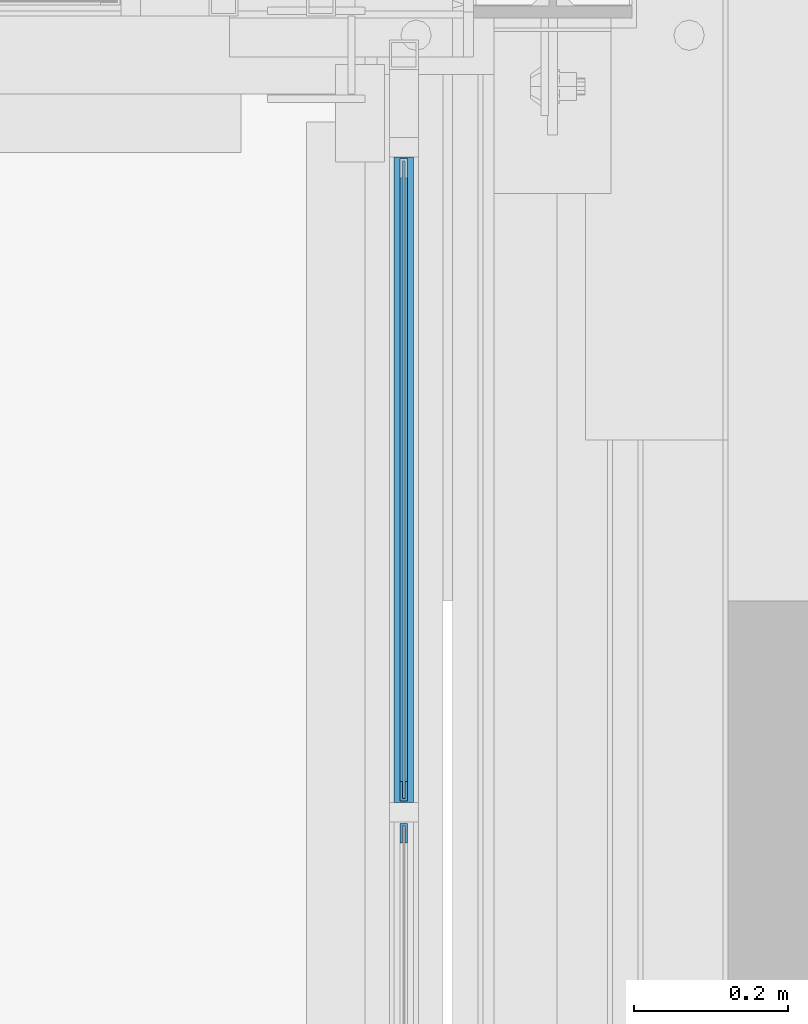
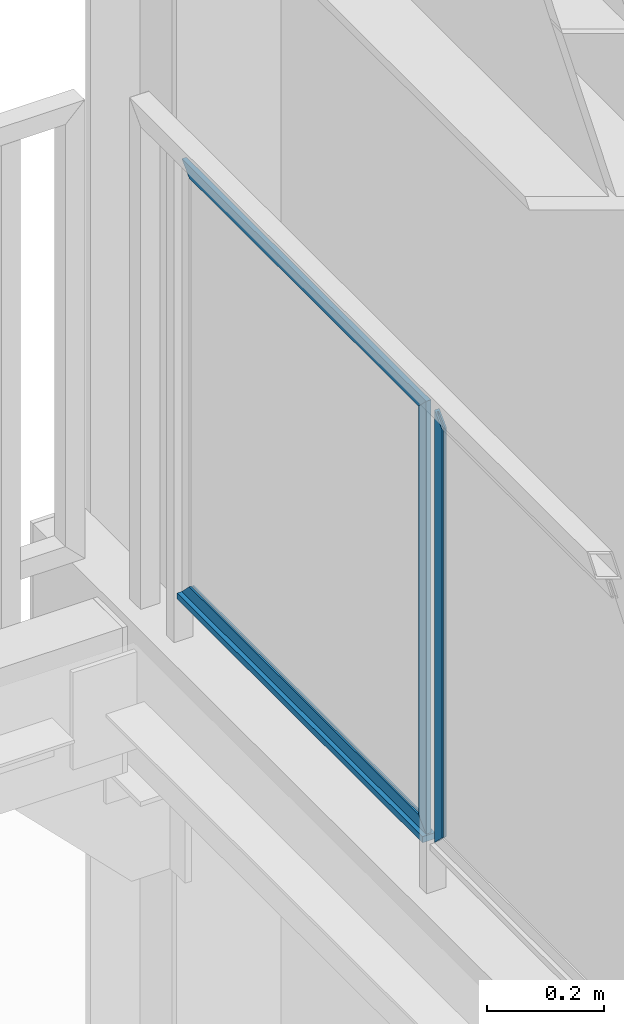
# One storey, part 949 of 1179: 4 beams, 1 member, 1 element without a shape of its own.
"""IFC2X3 building model written with IfcOpenShell, lengths in millimetres."""

from ifc_helpers import new_model, si_unit, frame, origin_with_axes, place, context, subcontext, project, spatial, faceted_brep, material, type_object, element, aggregate, save


model = new_model("IFC2X3")

# Units and contexts
model_context = context("Model", 3, precision=1e-05, world=origin_with_axes())
body_context = subcontext(model_context, "Body", "Model", "MODEL_VIEW")
ifc_project = project(units=[si_unit("LENGTHUNIT", "METRE", prefix="MILLI"), si_unit("AREAUNIT", "SQUARE_METRE"), si_unit("VOLUMEUNIT", "CUBIC_METRE"), si_unit("MASSUNIT", "GRAM", prefix="KILO"), si_unit("TIMEUNIT", "SECOND"), si_unit("PLANEANGLEUNIT", "RADIAN"), si_unit("SOLIDANGLEUNIT", "STERADIAN"), si_unit("THERMODYNAMICTEMPERATUREUNIT", "DEGREE_CELSIUS"), si_unit("LUMINOUSINTENSITYUNIT", "LUMEN")], contexts=[model_context])

# Site, building, storey
site_placement = place(None, origin_with_axes())
site = spatial("IfcSite", under=ifc_project, at=site_placement, CompositionType="ELEMENT")
building_placement = place(site_placement, origin_with_axes())
building = spatial("IfcBuilding", under=site, at=building_placement, Name="Undefined", CompositionType="ELEMENT")
storey_placement = place(building_placement, origin_with_axes())
storey = spatial("IfcBuildingStorey", under=building, at=storey_placement, Name="Undefined", CompositionType="ELEMENT", Elevation=0.0)

# Assembly, beams, member
assembly_placement = place(storey_placement, origin_with_axes())
assembly = element("IfcElementAssembly", 1, at=assembly_placement, inside=storey, Name="GUARDRAIL", AssemblyPlace="NOTDEFINED", PredefinedType="RIGID_FRAME")
ifc_material_1 = material(Name="STEEL/BUY-OUT")
beam_type = type_object("IfcBeamType", PredefinedType="NOTDEFINED")
beam_1_placement = place(assembly_placement, frame((24110.9500703529, 40049.0526242175, 2711.44999897165), z_axis=(0.0, 0.0, 1.0), x_axis=(0.0, -1.0, 0.0)))
beam_1 = element("IfcBeam", 2, at=beam_1_placement, type_object=beam_type, material=ifc_material_1, Name="U-EDGE", context=body_context, shape_type="Brep", body=[
    faceted_brep([(0.0, 1.58750000000146, -427.037571475466), (22.2249999999985, 1.58750000000146, -449.262071101228), (22.2249999999985, 4.76249999999709, -449.262071101228), (0.0, 4.76249999999709, -427.037571475466), (0.0, 7.9375, -427.037571475466), (25.4000000000015, 7.9375, -452.4375), (25.4000000000015, -1.58750000000146, -452.4375), (0.0, -1.58750000000146, -427.037571475466), (25.4000000000015, -1.58750000000146, 452.4375), (0.0, -1.58750000000146, 427.037500076054), (0.0, 1.58750000000146, 427.037500076054), (22.2249999999985, 1.58750000000146, 449.262500000033), (22.2249999999985, 4.76249999999709, 449.262500000033), (0.0, 4.76249999999709, 427.037500000033), (0.0, 7.9375, 427.037500000033), (25.4000000000015, 7.9375, 452.4375)], [[[0, 1, 2, 3, 4, 5, 6, 7]], [[7, 6, 8, 9]], [[0, 7, 9, 10]], [[1, 0, 10, 11]], [[2, 1, 11, 12]], [[3, 2, 12, 13]], [[4, 3, 13, 14]], [[5, 4, 14, 15]], [[6, 5, 15, 8]], [[14, 13, 12, 11, 10, 9, 8, 15]]]),
])
beam_2_placement = place(assembly_placement, frame((24110.9502052178, 40441.9591242175, 3138.48749897165), z_axis=(0.0, 1.0, 0.0), x_axis=(0.0, 0.0, 1.0)))
beam_2 = element("IfcBeam", 3, at=beam_2_placement, type_object=beam_type, material=ifc_material_1, Name="U-EDGE", context=body_context, shape_type="Brep", body=[
    faceted_brep([(0.0, 1.58750000000146, -392.906500000216), (22.2249999999785, 1.58750000000146, -415.131500000192), (22.2249999999603, 4.76236513509502, -415.131500000178), (-5.54791768081486e-11, 4.76236513509502, -392.906500000165), (-5.54791768081486e-11, 7.93736513509793, -392.906500000165), (25.3999999999414, 7.93736513509793, -418.306499999999), (25.3999999999969, -1.58750000000146, -418.306499999999), (0.0, -1.58750000000146, -392.906500000216), (25.3999999999969, -1.58750000000146, 418.306499999999), (0.0, -1.58750000000146, 392.90650078046), (0.0, 1.58750000000146, 392.90650078046), (22.2249999999785, 1.58750000000146, 415.131500780415), (22.2249999999603, 4.76236513509502, 415.131500780393), (-5.54791768081486e-11, 4.76236513509502, 392.90650078038), (-5.54791768081486e-11, 7.93736513509793, 392.90650078038), (25.3999999999414, 7.93736513509793, 418.306499999999)], [[[0, 1, 2, 3, 4, 5, 6, 7]], [[7, 6, 8, 9]], [[0, 7, 9, 10]], [[1, 0, 10, 11]], [[2, 1, 11, 12]], [[3, 2, 12, 13]], [[4, 3, 13, 14]], [[5, 4, 14, 15]], [[6, 5, 15, 8]], [[14, 13, 12, 11, 10, 9, 8, 15]]]),
])
beam_3_placement = place(assembly_placement, frame((24110.9502052178, 40441.9591242175, 2284.41249909944), z_axis=(0.0, 1.0, 0.0), x_axis=(0.0, 0.0, -1.0)))
beam_3 = element("IfcBeam", 4, at=beam_3_placement, type_object=beam_type, material=ifc_material_1, Name="U-EDGE", context=body_context, shape_type="Brep", body=[
    faceted_brep([(-5.45696821063757e-11, -4.76236513509502, -392.906500000157), (22.2249999999613, -4.76236513509502, -415.131500000178), (22.2249999999794, -1.58750000000146, -415.131500000192), (0.0, -1.58750000000146, -392.906500000216), (0.0, 1.58750000000146, -392.906500000216), (25.3999999999969, 1.58750000000146, -418.306499999999), (25.3999999999423, -7.93736513509793, -418.306499999999), (-5.45696821063757e-11, -7.93736513509793, -392.906500000157), (25.3999999999423, -7.93736513509793, 418.306499999999), (-5.45696821063757e-11, -7.93736513509793, 392.906500780409), (-5.45696821063757e-11, -4.76236513509502, 392.906500780409), (22.2249999999613, -4.76236513509502, 415.131500780422), (22.2249999999794, -1.58750000000146, 415.131500780437), (0.0, -1.58750000000146, 392.90650078046), (0.0, 1.58750000000146, 392.90650078046), (25.3999999999969, 1.58750000000146, 418.306499999999)], [[[0, 1, 2, 3, 4, 5, 6, 7]], [[7, 6, 8, 9]], [[0, 7, 9, 10]], [[1, 0, 10, 11]], [[2, 1, 11, 12]], [[3, 2, 12, 13]], [[4, 3, 13, 14]], [[5, 4, 14, 15]], [[6, 5, 15, 8]], [[14, 13, 12, 11, 10, 9, 8, 15]]]),
])
beam_4_placement = place(assembly_placement, frame((24110.9500703529, 39969.1489583341, 2711.44999945383), z_axis=(0.0, 0.0, 1.0), x_axis=(0.0, 1.0, 0.0)))
beam_4 = element("IfcBeam", 5, at=beam_4_placement, type_object=beam_type, material=ifc_material_1, Name="U-EDGE", context=body_context, shape_type="Brep", body=[
    faceted_brep([(2.91038304567337e-11, -4.76249999999709, -427.037499923914), (22.2250000000131, -4.76249999999709, -449.2624999239), (22.2250000000131, -1.58750000000146, -449.2624999239), (0.0, -1.58750000000146, -427.037499923886), (0.0, 1.58750000000146, -427.037499923886), (25.4000000439901, 1.58750000000146, -452.437500000357), (25.4000000476099, -7.93749999539432, -452.437500000422), (2.91038304567337e-11, -7.9375, -427.037499923914), (25.4000000000647, -7.9375, 452.4375), (1.29148247651756e-10, -7.9375, 427.037500076181), (1.29148247651756e-10, -4.76249999999709, 427.037500076181), (22.2250000000645, -4.76249999999709, 449.262500076118), (22.2250000000645, -1.58750000000146, 449.262500076118), (0.0, -1.58750000000146, 427.037500076054), (0.0, 1.58750000000146, 427.037500076054), (25.4000000000647, 1.58750000000146, 452.4375)], [[[0, 1, 2, 3, 4, 5, 6, 7]], [[8, 9, 7, 6]], [[9, 10, 0, 7]], [[10, 11, 1, 0]], [[11, 12, 2, 1]], [[12, 13, 3, 2]], [[13, 14, 4, 3]], [[14, 15, 5, 4]], [[15, 8, 6, 5]], [[14, 13, 12, 11, 10, 9, 8, 15]]]),
])
ifc_material_2 = material(Name="STEEL/A36")
member_type = type_object("IfcMemberType", PredefinedType="NOTDEFINED")
member_placement = place(assembly_placement, frame((24114.1250004143, 40009.2333333341, 2251.07500042314), z_axis=(1.0, 0.0, 0.0), x_axis=(0.0, 1.0, 0.0)))
member = element("IfcMember", 6, at=member_placement, type_object=member_type, material=ifc_material_2, Name="BOTTOM_RAIL", context=body_context, shape_type="Brep", body=[
    faceted_brep([(12.6999999999971, 6.35000000000036, -12.7000000000007), (12.6999999999971, 6.35000000000036, 12.7000000000007), (853.01666666659, 6.35000000000036, 12.7000000000007), (853.01666666659, 6.35000000000036, -12.7000000000007), (12.6999999999971, -6.35000000000036, 12.7000000000007), (853.01666666659, -6.35000000000036, 12.7000000000007), (12.6999999999971, -6.35000000000036, -12.7000000000007), (853.01666666659, -6.35000000000036, -12.7000000000007)], [[[0, 1, 2, 3]], [[1, 4, 5, 2]], [[4, 6, 7, 5]], [[6, 0, 3, 7]], [[5, 7, 3, 2]], [[6, 4, 1, 0]]]),
])
aggregate(assembly, [beam_1, beam_2, beam_3, beam_4, member])

save(model, "model.ifc")
